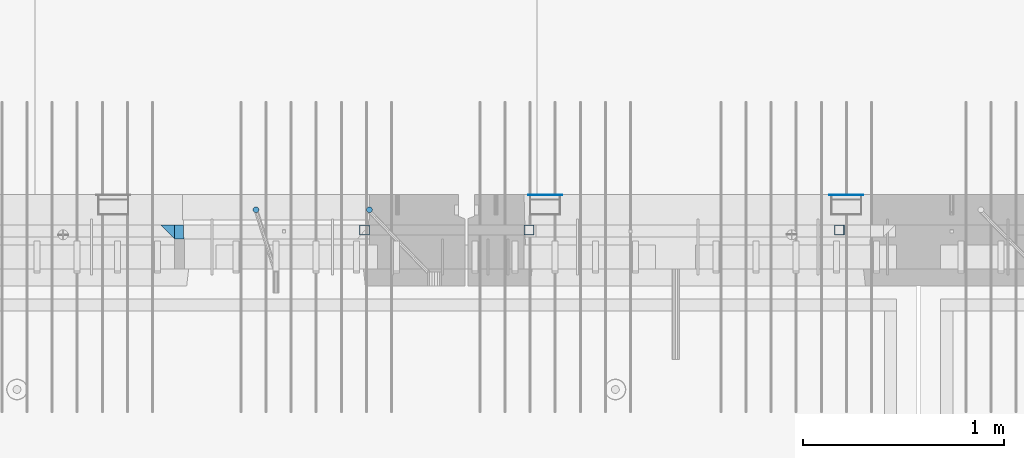
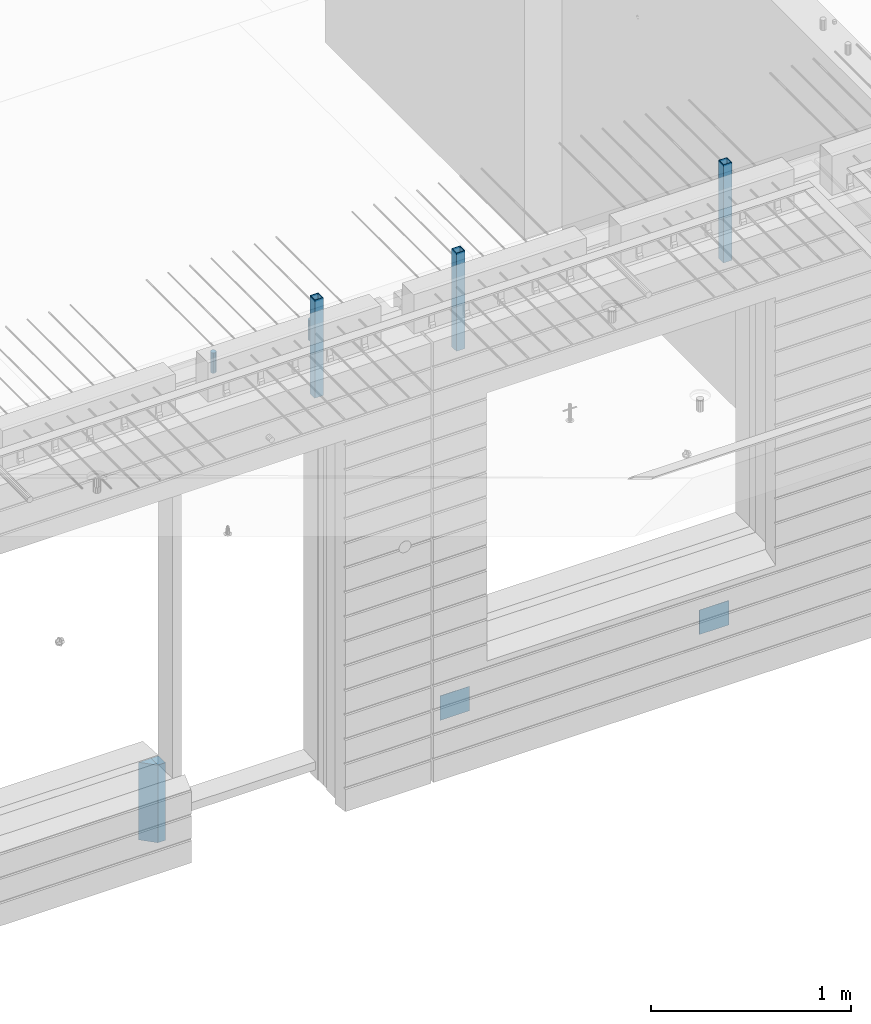
# One storey, part 17 of 341: 9 columns, 7 elements without a shape of their own.
"""IFC2X3 building model written with IfcOpenShell, lengths in millimetres."""

from ifc_helpers import new_model, si_unit, frame, origin_with_axes, place, context, subcontext, project, spatial, faceted_brep, material, type_object, element, aggregate, save


model = new_model("IFC2X3")

# Units and contexts
model_context = context("Model", 3, precision=1e-05, world=origin_with_axes())
body_context = subcontext(model_context, "Body", "Model", "MODEL_VIEW")
ifc_project = project(units=[si_unit("LENGTHUNIT", "METRE", prefix="MILLI"), si_unit("AREAUNIT", "SQUARE_METRE"), si_unit("VOLUMEUNIT", "CUBIC_METRE"), si_unit("MASSUNIT", "GRAM", prefix="KILO"), si_unit("TIMEUNIT", "SECOND"), si_unit("PLANEANGLEUNIT", "RADIAN"), si_unit("SOLIDANGLEUNIT", "STERADIAN"), si_unit("THERMODYNAMICTEMPERATUREUNIT", "DEGREE_CELSIUS"), si_unit("LUMINOUSINTENSITYUNIT", "LUMEN")], contexts=[model_context])

# Site, building, storey
site_placement = place(None, origin_with_axes())
site = spatial("IfcSite", under=ifc_project, at=site_placement, CompositionType="ELEMENT")
building_placement = place(site_placement, origin_with_axes())
building = spatial("IfcBuilding", under=site, at=building_placement, CompositionType="ELEMENT")
storey_placement = place(building_placement, origin_with_axes())
storey = spatial("IfcBuildingStorey", under=building, at=storey_placement, Name="5", CompositionType="ELEMENT", Elevation=0.0)

# Assembly, columns
assembly_1_placement = place(storey_placement, origin_with_axes())
assembly_1 = element("IfcElementAssembly", 1, at=assembly_1_placement, inside=storey, AssemblyPlace="NOTDEFINED", PredefinedType="REINFORCEMENT_UNIT")
ifc_material_1 = material(Name="CONCRETE/C35/45")
column_type_1 = type_object("IfcColumnType", PredefinedType="NOTDEFINED")
column_1_placement = place(assembly_1_placement, frame((24069.9998642727, 7815.0, 93755.0), z_axis=(1.0, 0.0, 0.0), x_axis=(0.0, 0.0, 1.0)))
column_1 = element("IfcColumn", 2, at=column_1_placement, type_object=column_type_1, material=ifc_material_1, Name="SK", context=body_context, shape_type="Brep", body=[
    faceted_brep([(0.0, -35.0, 35.0), (0.0, 35.0, 35.0), (0.0, -35.0, -35.0), (475.0, -35.0, 35.0), (475.0, -35.0, -35.0), (475.0, 35.0, 35.0)], [[[0, 1, 2]], [[3, 0, 2, 4]], [[3, 4, 5]], [[2, 1, 5, 4]], [[0, 3, 5, 1]]]),
])
column_type_2 = type_object("IfcColumnType", PredefinedType="NOTDEFINED")
column_2_placement = place(assembly_1_placement, frame((24129.9998642727, 7815.0, 93755.0), z_axis=(1.0, 0.0, 0.0), x_axis=(0.0, 0.0, 1.0)))
column_2 = element("IfcColumn", 3, at=column_2_placement, type_object=column_type_2, material=ifc_material_1, Name="SK", context=body_context, shape_type="Brep", body=[
    faceted_brep([(0.0, -35.0, -25.0), (0.0, 35.0, -25.0), (475.0, 35.0, -25.0), (475.0, -35.0, -25.0), (0.0, -35.0, 18.8457723764259), (0.0, 35.0, 20.640644171297), (475.0, 35.0, 20.640644171297), (475.0, -35.0, 18.8457723764259)], [[[0, 1, 2, 3]], [[1, 0, 4, 5]], [[2, 1, 5, 6]], [[3, 2, 6, 7]], [[0, 3, 7, 4]], [[6, 5, 4, 7]]]),
])
ifc_material_2 = material()
column_type_3 = type_object("IfcColumnType", Name="D30", PredefinedType="NOTDEFINED")
column_3_placement = place(assembly_1_placement, frame((24510.0000000048, 7924.99999999072, 96407.5), z_axis=(0.0, 1.0, 0.0), x_axis=(0.0, 0.0, 1.0)))
column_3 = element("IfcColumn", 4, at=column_3_placement, type_object=column_type_3, material=ifc_material_2, ObjectType="D30", context=body_context, shape_type="Brep", body=[
    faceted_brep([(0.0, -15.0, 0.0), (0.0, -12.9903810567666, -7.5), (125.0, -12.9903810567666, -7.5), (125.0, -15.0, 0.0), (0.0, -7.5, -12.9903810567666), (125.0, -7.5, -12.9903810567666), (0.0, 0.0, -15.0), (125.0, 0.0, -15.0), (0.0, 7.5, -12.9903810567666), (125.0, 7.5, -12.9903810567666), (0.0, 12.9903810567666, -7.5), (125.0, 12.9903810567666, -7.5), (0.0, 15.0, 0.0), (125.0, 15.0, 0.0), (0.0, 12.9903810567666, 7.5), (125.0, 12.9903810567666, 7.5), (0.0, 7.5, 12.9903810567666), (125.0, 7.5, 12.9903810567666), (0.0, 0.0, 15.0), (125.0, 0.0, 15.0), (0.0, -7.5, 12.9903810567666), (125.0, -7.5, 12.9903810567666), (0.0, -12.9903810567666, 7.5), (125.0, -12.9903810567666, 7.5)], [[[0, 1, 2, 3]], [[1, 4, 5, 2]], [[4, 6, 7, 5]], [[6, 8, 9, 7]], [[8, 10, 11, 9]], [[10, 12, 13, 11]], [[12, 14, 15, 13]], [[14, 16, 17, 15]], [[16, 18, 19, 17]], [[18, 20, 21, 19]], [[20, 22, 23, 21]], [[22, 0, 3, 23]], [[5, 7, 9, 11, 13, 15, 17, 19, 21, 23, 3, 2]], [[22, 20, 18, 16, 14, 12, 10, 8, 6, 4, 1, 0]]]),
])
column_4_placement = place(assembly_1_placement, frame((25074.9926665377, 7925.00000000707, 96407.5), z_axis=(0.0, 1.0, 0.0), x_axis=(0.0, 0.0, 1.0)))
column_4 = element("IfcColumn", 5, at=column_4_placement, type_object=column_type_3, material=ifc_material_2, ObjectType="D30", context=body_context, shape_type="Brep", body=[
    faceted_brep([(0.0, -15.0, 0.0), (0.0, -12.9903810567666, -7.5), (125.0, -12.9903810567666, -7.5), (125.0, -15.0, 0.0), (0.0, -7.5, -12.9903810567666), (125.0, -7.5, -12.9903810567666), (0.0, 0.0, -15.0), (125.0, 0.0, -15.0), (0.0, 7.5, -12.9903810567666), (125.0, 7.5, -12.9903810567666), (0.0, 12.9903810567666, -7.5), (125.0, 12.9903810567666, -7.5), (0.0, 15.0, 0.0), (125.0, 15.0, 0.0), (0.0, 12.9903810567666, 7.5), (125.0, 12.9903810567666, 7.5), (0.0, 7.5, 12.9903810567666), (125.0, 7.5, 12.9903810567666), (0.0, 0.0, 15.0), (125.0, 0.0, 15.0), (0.0, -7.5, 12.9903810567666), (125.0, -7.5, 12.9903810567666), (0.0, -12.9903810567666, 7.5), (125.0, -12.9903810567666, 7.5)], [[[0, 1, 2, 3]], [[1, 4, 5, 2]], [[4, 6, 7, 5]], [[6, 8, 9, 7]], [[8, 10, 11, 9]], [[10, 12, 13, 11]], [[12, 14, 15, 13]], [[14, 16, 17, 15]], [[16, 18, 19, 17]], [[18, 20, 21, 19]], [[20, 22, 23, 21]], [[22, 0, 3, 23]], [[5, 7, 9, 11, 13, 15, 17, 19, 21, 23, 3, 2]], [[22, 20, 18, 16, 14, 12, 10, 8, 6, 4, 1, 0]]]),
])

# Assemblies, columns
assembly_2_placement = place(storey_placement, origin_with_axes())
assembly_2 = element("IfcElementAssembly", 6, at=assembly_2_placement, inside=storey, AssemblyPlace="NOTDEFINED", PredefinedType="REINFORCEMENT_UNIT")
assembly_3_placement = place(assembly_2_placement, origin_with_axes())
assembly_3 = element("IfcElementAssembly", 7, at=assembly_3_placement, Name="Steel Assembly", AssemblyPlace="NOTDEFINED", PredefinedType="NOTDEFINED")
ifc_material_3 = material(Name="Undefined")
column_type_4 = type_object("IfcColumnType", PredefinedType="NOTDEFINED")
column_5_placement = place(assembly_3_placement, frame((25950.0, 7998.99999999844, 93754.9999999985), z_axis=(0.0, 1.0, 0.0), x_axis=(0.0, 0.0, 1.0)))
column_5 = element("IfcColumn", 8, at=column_5_placement, type_object=column_type_4, material=ifc_material_3, Name="SPK2", context=body_context, shape_type="Brep", body=[
    faceted_brep([(0.0, 85.0, -1.0), (0.0, 85.0, 1.0), (150.0, 85.0, 1.0), (150.0, 85.0, -1.0), (0.0, -85.0, 1.0), (150.0, -85.0, 1.0), (0.0, -85.0, -1.0), (150.0, -85.0, -1.0)], [[[0, 1, 2, 3]], [[1, 4, 5, 2]], [[4, 6, 7, 5]], [[6, 0, 3, 7]], [[5, 7, 3, 2]], [[6, 4, 1, 0]]]),
])
aggregate(assembly_3, [column_5])
assembly_4_placement = place(assembly_2_placement, origin_with_axes())
assembly_4 = element("IfcElementAssembly", 9, at=assembly_4_placement, Name="Steel Assembly", AssemblyPlace="NOTDEFINED", PredefinedType="NOTDEFINED")
column_6_placement = place(assembly_4_placement, frame((27450.0, 7998.99999999844, 93754.9999999985), z_axis=(0.0, 1.0, 0.0), x_axis=(0.0, 0.0, 1.0)))
column_6 = element("IfcColumn", 10, at=column_6_placement, type_object=column_type_4, material=ifc_material_3, Name="SPK2", context=body_context, shape_type="Brep", body=[
    faceted_brep([(0.0, 85.0, -1.0), (0.0, 85.0, 1.0), (150.0, 85.0, 1.0), (150.0, 85.0, -1.0), (0.0, -85.0, 1.0), (150.0, -85.0, 1.0), (0.0, -85.0, -1.0), (150.0, -85.0, -1.0)], [[[0, 1, 2, 3]], [[1, 4, 5, 2]], [[4, 6, 7, 5]], [[6, 0, 3, 7]], [[5, 7, 3, 2]], [[6, 4, 1, 0]]]),
])
aggregate(assembly_4, [column_6])

# Assembly
assembly_5_placement = place(assembly_1_placement, origin_with_axes())
assembly_5 = element("IfcElementAssembly", 11, at=assembly_5_placement, Name="Steel Assembly", AssemblyPlace="NOTDEFINED", PredefinedType="RIGID_FRAME")

aggregate(assembly_1, [column_3, column_4, assembly_5, column_1, column_2])

# Column
ifc_material_4 = material(Name="STEEL/S355J2")
column_type_5 = type_object("IfcColumnType", Name="50X50X3", PredefinedType="NOTDEFINED")
column_7_placement = place(assembly_5_placement, frame((25050.0, 7825.0, 96140.0), z_axis=(-1.0, 3.00000001838171e-08, 0.0), x_axis=(0.0, 0.0, 1.0)))
column_7 = element("IfcColumn", 12, at=column_7_placement, type_object=column_type_5, material=ifc_material_4, ObjectType="50X50X3", context=body_context, shape_type="Brep", body=[
    faceted_brep([(0.0, 22.0, -22.0), (0.0, -22.0, -22.0), (600.0, -22.0, -22.0), (600.0, 22.0, -22.0), (0.0, -22.0, 22.0), (600.0, -22.0, 22.0), (0.0, 22.0, 22.0), (600.0, 22.0, 22.0), (0.0, 25.0, -25.0), (0.0, 25.0, 25.0), (600.0, 25.0, 25.0), (600.0, 25.0, -25.0), (0.0, -25.0, 25.0), (600.0, -25.0, 25.0), (0.0, -25.0, -25.0), (600.0, -25.0, -25.0)], [[[0, 1, 2, 3]], [[1, 4, 5, 2]], [[4, 6, 7, 5]], [[6, 0, 3, 7]], [[8, 9, 10, 11]], [[9, 12, 13, 10]], [[12, 14, 15, 13]], [[14, 8, 11, 15]], [[13, 15, 11, 10], [5, 7, 3, 2]], [[14, 12, 9, 8], [6, 4, 1, 0]]]),
])

aggregate(assembly_5, [column_7])

# Assembly, column
assembly_6_placement = place(assembly_2_placement, origin_with_axes())
assembly_6 = element("IfcElementAssembly", 13, at=assembly_6_placement, Name="Steel Assembly", AssemblyPlace="NOTDEFINED", PredefinedType="RIGID_FRAME")
column_8_placement = place(assembly_6_placement, frame((25870.0, 7825.0, 96140.0), z_axis=(-1.0, 3.00000001838171e-08, 0.0), x_axis=(0.0, 0.0, 1.0)))
column_8 = element("IfcColumn", 14, at=column_8_placement, type_object=column_type_5, material=ifc_material_4, ObjectType="50X50X3", context=body_context, shape_type="Brep", body=[
    faceted_brep([(0.0, 22.0, -22.0), (0.0, -22.0, -22.0), (600.0, -22.0, -22.0), (600.0, 22.0, -22.0), (0.0, -22.0, 22.0), (600.0, -22.0, 22.0), (0.0, 22.0, 22.0), (600.0, 22.0, 22.0), (0.0, 25.0, -25.0), (0.0, 25.0, 25.0), (600.0, 25.0, 25.0), (600.0, 25.0, -25.0), (0.0, -25.0, 25.0), (600.0, -25.0, 25.0), (0.0, -25.0, -25.0), (600.0, -25.0, -25.0)], [[[0, 1, 2, 3]], [[1, 4, 5, 2]], [[4, 6, 7, 5]], [[6, 0, 3, 7]], [[8, 9, 10, 11]], [[9, 12, 13, 10]], [[12, 14, 15, 13]], [[14, 8, 11, 15]], [[13, 15, 11, 10], [5, 7, 3, 2]], [[14, 12, 9, 8], [6, 4, 1, 0]]]),
])
aggregate(assembly_6, [column_8])

# Assembly
assembly_7_placement = place(assembly_2_placement, origin_with_axes())
assembly_7 = element("IfcElementAssembly", 15, at=assembly_7_placement, Name="Steel Assembly", AssemblyPlace="NOTDEFINED", PredefinedType="RIGID_FRAME")

aggregate(assembly_2, [assembly_3, assembly_4, assembly_6, assembly_7])

# Column
column_9_placement = place(assembly_7_placement, frame((27415.0, 7825.0, 96140.0), z_axis=(-1.0, 3.00000001838171e-08, 0.0), x_axis=(0.0, 0.0, 1.0)))
column_9 = element("IfcColumn", 16, at=column_9_placement, type_object=column_type_5, material=ifc_material_4, ObjectType="50X50X3", context=body_context, shape_type="Brep", body=[
    faceted_brep([(0.0, 22.0, -22.0), (0.0, -22.0, -22.0), (600.0, -22.0, -22.0), (600.0, 22.0, -22.0), (0.0, -22.0, 22.0), (600.0, -22.0, 22.0), (0.0, 22.0, 22.0), (600.0, 22.0, 22.0), (0.0, 25.0, -25.0), (0.0, 25.0, 25.0), (600.0, 25.0, 25.0), (600.0, 25.0, -25.0), (0.0, -25.0, 25.0), (600.0, -25.0, 25.0), (0.0, -25.0, -25.0), (600.0, -25.0, -25.0)], [[[0, 1, 2, 3]], [[1, 4, 5, 2]], [[4, 6, 7, 5]], [[6, 0, 3, 7]], [[8, 9, 10, 11]], [[9, 12, 13, 10]], [[12, 14, 15, 13]], [[14, 8, 11, 15]], [[13, 15, 11, 10], [5, 7, 3, 2]], [[14, 12, 9, 8], [6, 4, 1, 0]]]),
])

aggregate(assembly_7, [column_9])

save(model, "model.ifc")
